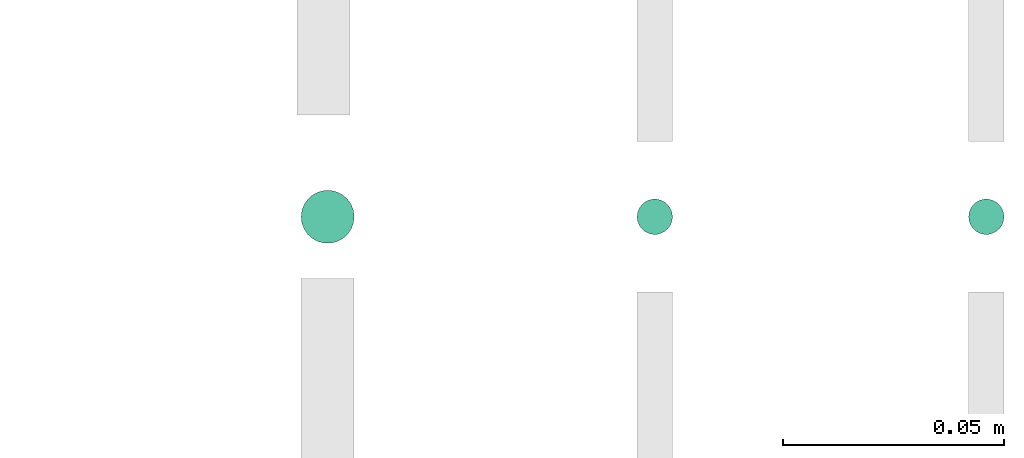
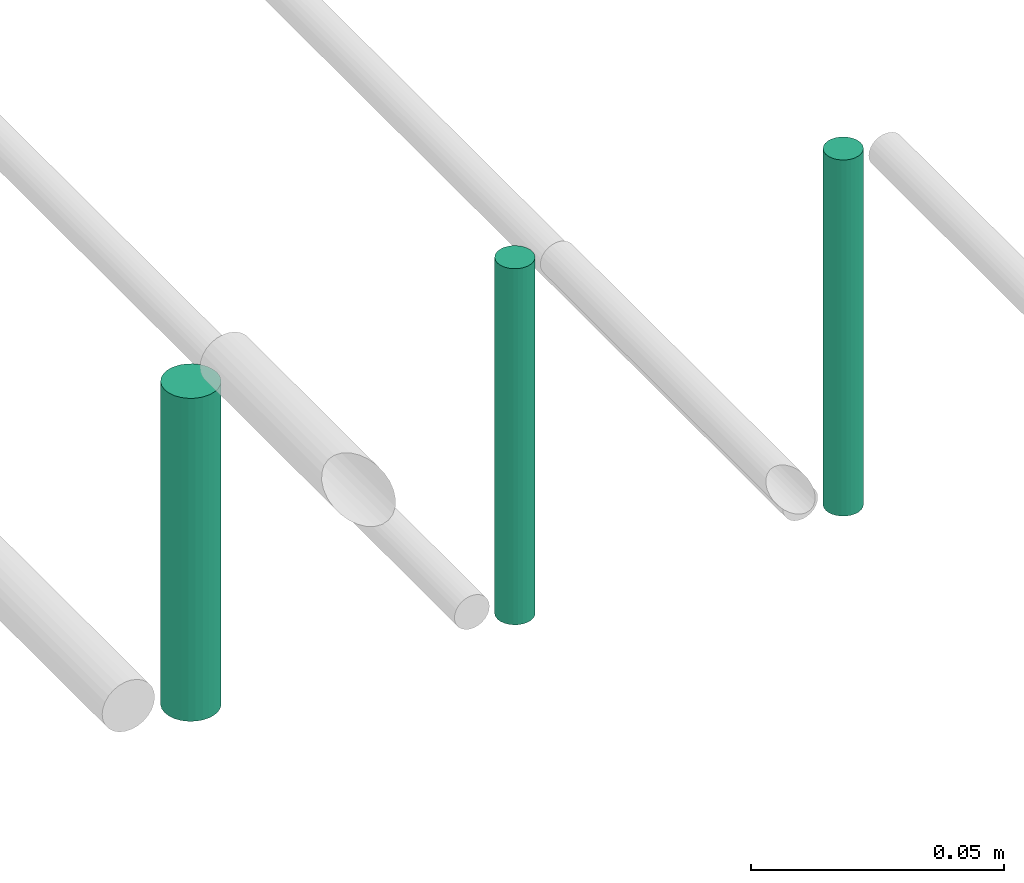
# One storey, part 305 of 331: 3 flow segments.
"""IFC2X3 building model written with IfcOpenShell, lengths in millimetres."""

from ifc_helpers import new_model, entity, si_unit, converted_unit, derived_unit, direction, frame, origin, origin_2d_with_axis, place, context, subcontext, project, spatial, circle, extrude, type_object, element, save


model = new_model("IFC2X3")

# Units and contexts
model_context = context("Model", 3, precision=0.01, world=origin(), true_north=direction((6.12303176911189e-17, 1.0)))
body_context = subcontext(model_context, "Body", "Model", "MODEL_VIEW")
ifc_project = project(units=[si_unit("LENGTHUNIT", "METRE", prefix="MILLI"), si_unit("AREAUNIT", "SQUARE_METRE"), si_unit("VOLUMEUNIT", "CUBIC_METRE"), converted_unit("PLANEANGLEUNIT", "DEGREE", entity("IfcRatioMeasure", 0.0174532925199433), si_unit("PLANEANGLEUNIT", "RADIAN"), dimensions=[0, 0, 0, 0, 0, 0, 0]), si_unit("MASSUNIT", "GRAM", prefix="KILO"), derived_unit("MASSDENSITYUNIT", [(si_unit("MASSUNIT", "GRAM", prefix="KILO"), 1), (si_unit("LENGTHUNIT", "METRE"), -3)]), derived_unit("MOMENTOFINERTIAUNIT", [(si_unit("LENGTHUNIT", "METRE"), 4)]), si_unit("TIMEUNIT", "SECOND"), si_unit("FREQUENCYUNIT", "HERTZ"), si_unit("THERMODYNAMICTEMPERATUREUNIT", "DEGREE_CELSIUS"), derived_unit("THERMALTRANSMITTANCEUNIT", [(si_unit("MASSUNIT", "GRAM", prefix="KILO"), 1), (si_unit("THERMODYNAMICTEMPERATUREUNIT", "KELVIN"), -1), (si_unit("TIMEUNIT", "SECOND"), -3)]), derived_unit("VOLUMETRICFLOWRATEUNIT", [(si_unit("LENGTHUNIT", "METRE"), 3), (si_unit("TIMEUNIT", "SECOND"), -1)]), derived_unit("MASSFLOWRATEUNIT", [(si_unit("MASSUNIT", "GRAM", prefix="KILO"), 1), (si_unit("TIMEUNIT", "SECOND"), -1)]), derived_unit("ROTATIONALFREQUENCYUNIT", [(si_unit("TIMEUNIT", "SECOND"), -1)]), si_unit("ELECTRICCURRENTUNIT", "AMPERE"), si_unit("ELECTRICVOLTAGEUNIT", "VOLT"), si_unit("POWERUNIT", "WATT"), si_unit("FORCEUNIT", "NEWTON", prefix="KILO"), si_unit("ILLUMINANCEUNIT", "LUX"), si_unit("LUMINOUSFLUXUNIT", "LUMEN"), si_unit("LUMINOUSINTENSITYUNIT", "CANDELA"), derived_unit("USERDEFINED", [(si_unit("MASSUNIT", "GRAM", prefix="KILO"), -1), (si_unit("LENGTHUNIT", "METRE"), -2), (si_unit("TIMEUNIT", "SECOND"), 3), (si_unit("LUMINOUSFLUXUNIT", "LUMEN"), 1)]), derived_unit("LINEARVELOCITYUNIT", [(si_unit("LENGTHUNIT", "METRE"), 1), (si_unit("TIMEUNIT", "SECOND"), -1)]), si_unit("PRESSUREUNIT", "PASCAL"), derived_unit("USERDEFINED", [(si_unit("LENGTHUNIT", "METRE"), -2), (si_unit("MASSUNIT", "GRAM", prefix="KILO"), 1), (si_unit("TIMEUNIT", "SECOND"), -2)]), derived_unit("LINEARFORCEUNIT", [(si_unit("MASSUNIT", "GRAM", prefix="KILO"), 1), (si_unit("LENGTHUNIT", "METRE"), 1), (si_unit("TIMEUNIT", "SECOND"), -2), (si_unit("LENGTHUNIT", "METRE"), -1)]), derived_unit("PLANARFORCEUNIT", [(si_unit("MASSUNIT", "GRAM", prefix="KILO"), 1), (si_unit("LENGTHUNIT", "METRE"), 1), (si_unit("TIMEUNIT", "SECOND"), -2), (si_unit("LENGTHUNIT", "METRE"), -2)])], contexts=[model_context])

# Site, building, storey
site_placement = place(None, frame((0.0, -0.00077364408347762, 0.0)))
site = spatial("IfcSite", under=ifc_project, at=site_placement, CompositionType="ELEMENT")
building_placement = place(site_placement, origin())
building = spatial("IfcBuilding", under=site, at=building_placement, CompositionType="ELEMENT")
storey_placement = place(building_placement, origin())
storey = spatial("IfcBuildingStorey", under=building, at=storey_placement, CompositionType="ELEMENT", Elevation=0.0)

# Flow segments
pipe_segment_type = type_object("IfcPipeSegmentType", PredefinedType="NOTDEFINED")
flow_segment_placement = place(storey_placement, frame((68012.5100168243, 3904.90458047169, 7264.0)))
element("IfcFlowSegment", 1, at=flow_segment_placement, inside=storey, type_object=pipe_segment_type, context=body_context, shape_type="SweptSolid", body=[
    extrude(circle(Radius=6.0, at=origin_2d_with_axis()), frame((7.59527223591454, 7.59527223591616, 0.0), z_axis=(0.0, 0.0, 1.0), x_axis=(-1.0, 0.0, 0.0)), (0.0, 0.0, 1.0), 78.0000000000007),
])
for number, where in (
    (2, (68088.5232052591, 3906.90458047169, 7260.0)),
    (3, (68163.5232052591, 3906.90458047169, 7260.0)),
):
    element("IfcFlowSegment", number, at=place(storey_placement, frame(where)), inside=storey, type_object=pipe_segment_type, context=body_context, shape_type="SweptSolid", body=[
        extrude(circle(Radius=4.0, at=origin_2d_with_axis()), frame((5.59527223591499, 5.59527223591607, 0.0), z_axis=(0.0, 0.0, 1.0), x_axis=(-1.0, 0.0, 0.0)), (0.0, 0.0, 1.0), 86.000000000001),
    ])

save(model, "model.ifc")
